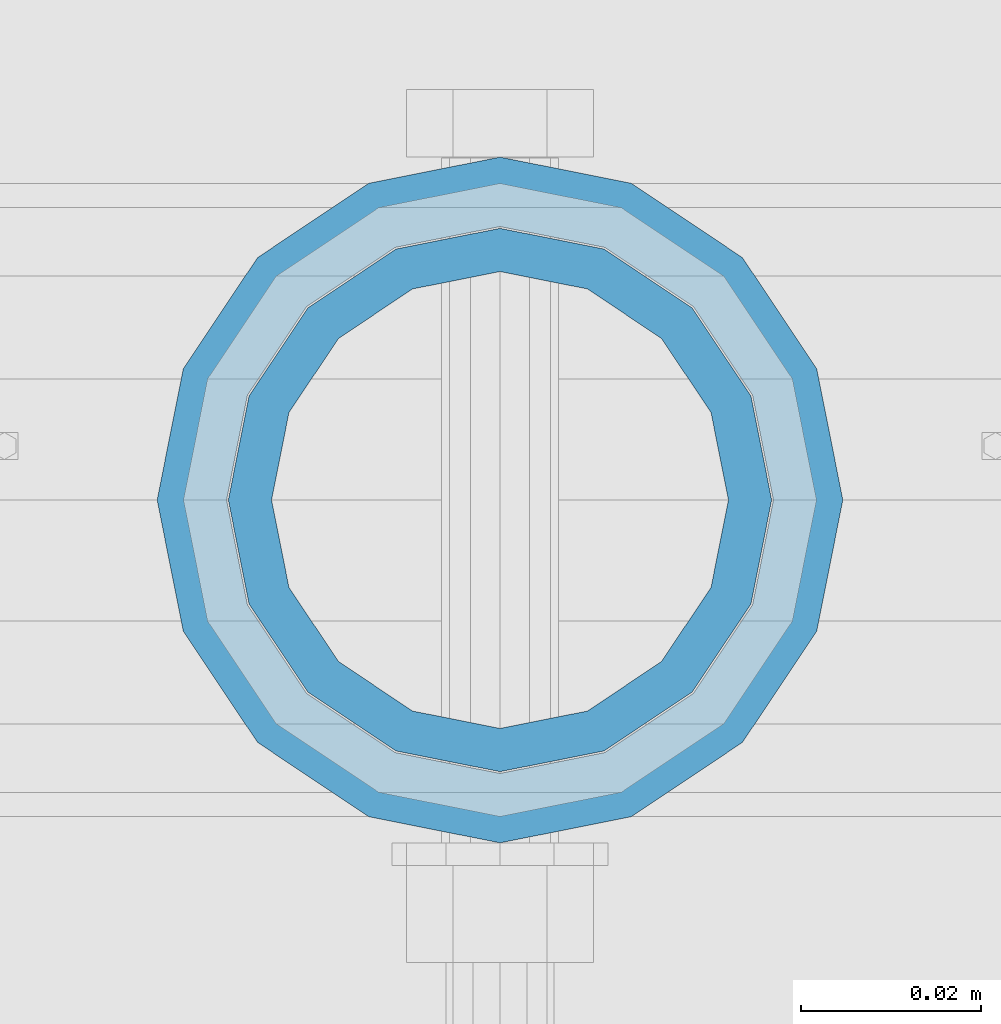
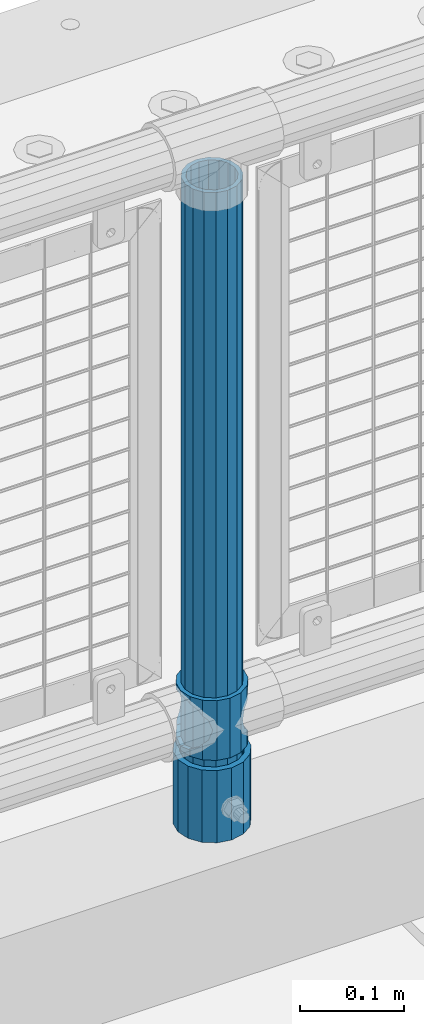
# One storey, part 55 of 193: 3 columns.
"""IFC2X3 building model written with IfcOpenShell, lengths in millimetres."""

from ifc_helpers import new_model, si_unit, frame, origin_with_axes, place, context, subcontext, project, spatial, faceted_brep, material, type_object, element, save


model = new_model("IFC2X3")

# Units and contexts
model_context = context("Model", 3, precision=1e-05, world=origin_with_axes())
body_context = subcontext(model_context, "Body", "Model", "MODEL_VIEW")
ifc_project = project(units=[si_unit("LENGTHUNIT", "METRE", prefix="MILLI"), si_unit("AREAUNIT", "SQUARE_METRE"), si_unit("VOLUMEUNIT", "CUBIC_METRE"), si_unit("MASSUNIT", "GRAM", prefix="KILO"), si_unit("TIMEUNIT", "SECOND"), si_unit("PLANEANGLEUNIT", "RADIAN"), si_unit("SOLIDANGLEUNIT", "STERADIAN"), si_unit("THERMODYNAMICTEMPERATUREUNIT", "DEGREE_CELSIUS"), si_unit("LUMINOUSINTENSITYUNIT", "LUMEN")], contexts=[model_context])

# Site, building, storey
site_placement = place(None, origin_with_axes())
site = spatial("IfcSite", under=ifc_project, at=site_placement, CompositionType="ELEMENT")
building_placement = place(site_placement, origin_with_axes())
building = spatial("IfcBuilding", under=site, at=building_placement, Name="Standard", CompositionType="ELEMENT")
storey_placement = place(building_placement, origin_with_axes())
storey = spatial("IfcBuildingStorey", under=building, at=storey_placement, Name="Undefined", CompositionType="ELEMENT", Elevation=0.0)

# Columns
ifc_material_1 = material(Name="Misc_Undefined")
column_type_1 = type_object("IfcColumnType", PredefinedType="NOTDEFINED")
column_1_placement = place(storey_placement, frame((-40171.0, 28664.5, 263.02), z_axis=(-1.0, 0.0, 0.0), x_axis=(0.0, 0.0, 1.0)))
element("IfcColumn", 1, at=column_1_placement, inside=storey, type_object=column_type_1, material=ifc_material_1, context=body_context, shape_type="Brep", body=[
    faceted_brep([(56.6106908090114, 21.46069080901, -21.46069080901), (56.6106908090114, 21.46069080901, -27.1226768591041), (61.9623795176744, 13.4513226476338, -32.4743655677703), (63.1897438117172, 11.614442172282, -32.8397438117245), (63.1897438117172, 11.614442172282, -28.0397438117179), (46.7644421722801, 28.0397438117179, -11.614442172282), (46.7644421722801, 28.0397438117179, -20.0882031229849), (51.5310424080006, 24.8548033587067, -24.8548033587067), (35.1500000000015, 30.35, 0.0), (35.1499999999996, 30.3499999999985, -16.6306603983685), (23.5355578277192, 28.0397438117179, -11.614442172282), (23.5355578277192, 28.0397438117179, -20.0882031229849), (13.6893091909879, 21.46069080901, -21.46069080901), (13.6893091909879, 21.46069080901, -27.1226768591041), (18.7689575919987, 24.8548033587067, -24.8548033587067), (7.11025618828211, 11.614442172282, -28.0397438117179), (7.11025618828211, 11.614442172282, -32.8397438117245), (8.33762048232262, 13.4513226476338, -32.4743655677703), (4.79999999999961, 0.0, -30.3499999999985), (4.79999999999961, 0.0, -35.1500000000015), (7.11025618828211, -11.614442172282, -28.0397438117179), (7.11025618828211, -11.614442172282, -32.8397438117172), (13.6893091909879, -21.46069080901, -21.46069080901), (13.6893091909879, -21.46069080901, -27.1226768591114), (8.33762048232484, -13.4513226476338, -32.4743655677703), (23.5355578277191, -28.0397438117179, -11.614442172282), (23.5355578277191, -28.0397438117179, -20.0882031229812), (18.7689575919921, -24.8548033587067, -24.8548033587067), (35.1500000000015, -30.35, 0.0), (35.1499999999996, -30.3499999999985, -16.6306603983721), (46.7644421722801, -28.0397438117179, -11.614442172282), (46.7644421722801, -28.0397438117179, -20.0882031229812), (56.6106908090114, -21.46069080901, -21.46069080901), (56.6106908090114, -21.46069080901, -27.1226768591114), (51.5310424080006, -24.8548033587067, -24.8548033587067), (63.1897438117172, -11.614442172282, -28.0397438117179), (63.1897438117172, -11.614442172282, -32.8397438117172), (61.9623795176767, -13.4513226476338, -32.4743655677703), (65.4999999999997, 0.0, -30.3499999999985), (65.4999999999997, 0.0, -35.1500000000015), (0.0, -28.0397438117179, -11.614442172282), (0.0, -30.3499999999985, 0.0), (0.0, -21.46069080901, -21.46069080901), (0.0, -11.614442172282, -28.0397438117179), (0.0, 0.0, -30.3499999999985), (0.0, 11.614442172282, -28.0397438117179), (0.0, 21.46069080901, -21.46069080901), (0.0, 28.0397438117179, -11.614442172282), (0.0, 30.3499999999985, 0.0), (0.0, 28.0397438117179, 11.614442172282), (23.5355578277192, 28.0397438117179, 11.614442172282), (0.0, 21.46069080901, 21.46069080901), (13.6893091909879, 21.46069080901, 21.46069080901), (0.0, 11.614442172282, 28.0397438117179), (7.11025618828211, 11.614442172282, 28.0397438117179), (0.0, 0.0, 30.3499999999985), (4.79999999999961, 0.0, 30.3499999999985), (0.0, -11.614442172282, 28.0397438117179), (7.11025618828205, -11.614442172282, 28.0397438117179), (0.0, -21.46069080901, 21.46069080901), (13.6893091909879, -21.46069080901, 21.46069080901), (0.0, -28.0397438117179, 11.614442172282), (23.5355578277191, -28.0397438117179, 11.614442172282), (0.0, -32.4743655677703, 13.4513226476338), (0.0, -35.1500000000015, 0.0), (70.2999999999993, -35.1500000000015, 0.0), (70.2999999999993, -32.4743655677703, 13.4513226476338), (0.0, 13.4513226476338, -32.4743655677703), (0.0, 24.8548033587067, -24.8548033587067), (0.0, 0.0, -35.1500000000015), (0.0, -13.4513226476338, -32.4743655677703), (0.0, -24.8548033587067, -24.8548033587067), (0.0, -24.8548033587067, 24.8548033587067), (0.0, -13.4513226476338, 32.4743655677703), (0.0, 0.0, 35.1500000000015), (0.0, 13.4513226476338, 32.4743655677703), (0.0, 24.8548033587067, 24.8548033587067), (0.0, 32.4743655677703, 13.4513226476338), (0.0, 35.1500000000015, 0.0), (0.0, 32.4743655677703, -13.4513226476338), (0.0, -32.4743655677703, -13.4513226476338), (70.2999999999993, 32.4743655677703, 13.4513226476338), (70.2999999999993, 35.1500000000015, 0.0), (70.2999999999993, 32.4743655677703, -13.4513226476338), (70.2999999999993, 24.8548033587067, -24.8548033587067), (70.2999999999993, 13.4513226476338, -32.4743655677703), (70.2999999999993, 0.0, -35.1500000000015), (70.2999999999993, -13.4513226476338, -32.4743655677703), (70.2999999999993, -24.8548033587067, -24.8548033587067), (70.2999999999993, -32.4743655677703, -13.4513226476338), (70.2999999999993, 28.0397438117179, 11.614442172282), (70.2999999999993, 21.46069080901, 21.46069080901), (56.6106908090114, 21.46069080901, 21.46069080901), (46.7644421722801, 28.0397438117179, 11.614442172282), (70.2999999999993, 11.614442172282, 28.0397438117179), (63.1897438117172, 11.614442172282, 28.0397438117179), (70.2999999999993, 0.0, 30.3499999999985), (65.4999999999997, 0.0, 30.3499999999985), (70.2999999999993, -11.614442172282, 28.0397438117179), (63.1897438117172, -11.614442172282, 28.0397438117179), (70.2999999999993, -21.46069080901, 21.46069080901), (56.6106908090114, -21.46069080901, 21.46069080901), (70.2999999999993, -28.0397438117179, 11.614442172282), (46.7644421722801, -28.0397438117179, 11.614442172282), (70.2999999999993, -11.614442172282, -28.0397438117179), (70.2999999999993, 0.0, -30.3499999999985), (70.2999999999993, -21.46069080901, -21.46069080901), (70.2999999999993, -28.0397438117179, -11.614442172282), (70.2999999999993, -30.3499999999985, 0.0), (70.2999999999993, 24.8548033587067, 24.8548033587067), (70.2999999999993, 13.4513226476338, 32.4743655677703), (70.2999999999993, 0.0, 35.1500000000015), (70.2999999999993, -13.4513226476338, 32.4743655677703), (70.2999999999993, -24.8548033587067, 24.8548033587067), (70.2999999999993, 30.3499999999985, 0.0), (70.2999999999993, 28.0397438117179, -11.614442172282), (70.2999999999993, 21.46069080901, -21.46069080901), (70.2999999999993, 11.614442172282, -28.0397438117179), (61.9623795176742, 13.4513226476338, 32.4743655677703), (51.5310424080006, 24.8548033587067, 24.8548033587067), (56.6106908090114, 21.46069080901, 27.1226768591077), (65.4999999999997, 0.0, 35.1500000000015), (63.1897438117172, 11.614442172282, 32.8397438117136), (63.1897438117172, -11.614442172282, 32.8397438117136), (61.9623795176767, -13.4513226476338, 32.4743655677703), (56.6106908090114, -21.46069080901, 27.1226768591041), (51.5310424080006, -24.8548033587067, 24.8548033587067), (18.7689575919921, -24.8548033587067, 24.8548033587067), (46.7644421722801, -28.0397438117179, 20.0882031229812), (35.1499999999996, -30.3499999999985, 16.6306603983685), (23.5355578277191, -28.0397438117179, 20.0882031229812), (8.33762048232512, -13.4513226476338, 32.4743655677703), (13.6893091909879, -21.46069080901, 27.1226768591041), (4.79999999999961, 0.0, 35.1500000000015), (7.11025618828205, -11.614442172282, 32.8397438117136), (7.11025618828211, 11.614442172282, 32.8397438117136), (8.3376204823229, 13.4513226476338, 32.4743655677703), (13.6893091909879, 21.46069080901, 27.1226768591077), (18.7689575919987, 24.8548033587067, 24.8548033587067), (23.5355578277192, 28.0397438117179, 20.0882031229739), (35.1499999999996, 30.3499999999985, 16.6306603983576), (46.7644421722801, 28.0397438117179, 20.0882031229739)], [[[0, 1, 2, 3, 4]], [[5, 6, 7, 1, 0]], [[8, 9, 6, 5]], [[10, 11, 9, 8]], [[12, 13, 14, 11, 10]], [[15, 16, 17, 13, 12]], [[18, 19, 16, 15]], [[20, 21, 19, 18]], [[22, 23, 24, 21, 20]], [[25, 26, 27, 23, 22]], [[28, 29, 26, 25]], [[30, 31, 29, 28]], [[32, 33, 34, 31, 30]], [[35, 36, 37, 33, 32]], [[38, 39, 36, 35]], [[4, 3, 39, 38]], [[40, 41, 28, 25]], [[42, 40, 25, 22]], [[43, 42, 22, 20]], [[44, 43, 20, 18]], [[45, 44, 18, 15]], [[46, 45, 15, 12]], [[47, 46, 12, 10]], [[48, 47, 10, 8]], [[49, 48, 8, 50]], [[51, 49, 50, 52]], [[53, 51, 52, 54]], [[55, 53, 54, 56]], [[57, 55, 56, 58]], [[59, 57, 58, 60]], [[61, 59, 60, 62]], [[41, 61, 62, 28]], [[63, 64, 65, 66]], [[17, 67, 68, 14, 13]], [[19, 69, 67, 17, 16]], [[70, 69, 19, 21, 24]], [[71, 70, 24, 23, 27]], [[63, 72, 73, 74, 75, 76, 77, 78, 79, 68, 67, 69, 70, 71, 80, 64], [40, 42, 43, 44, 45, 46, 47, 48, 49, 51, 53, 55, 57, 59, 61, 41]], [[78, 77, 81, 82]], [[79, 78, 82, 83]], [[14, 68, 79, 83, 84, 7, 6, 9, 11]], [[84, 85, 2, 1, 7]], [[85, 86, 39, 3, 2]], [[37, 87, 88, 34, 33]], [[39, 86, 87, 37, 36]], [[34, 88, 89, 80, 71, 27, 26, 29, 31]], [[64, 80, 89, 65]], [[90, 91, 92, 93]], [[91, 94, 95, 92]], [[94, 96, 97, 95]], [[96, 98, 99, 97]], [[98, 100, 101, 99]], [[100, 102, 103, 101]], [[104, 105, 38, 35]], [[106, 104, 35, 32]], [[107, 106, 32, 30]], [[108, 107, 30, 28]], [[102, 108, 28, 103]], [[88, 87, 86, 85, 84, 83, 82, 81, 109, 110, 111, 112, 113, 66, 65, 89], [100, 98, 96, 94, 91, 90, 114, 115, 116, 117, 105, 104, 106, 107, 108, 102]], [[118, 110, 109, 119, 120]], [[121, 111, 110, 118, 122]], [[112, 111, 121, 123, 124]], [[113, 112, 124, 125, 126]], [[127, 72, 63, 66, 113, 126, 128, 129, 130]], [[131, 73, 72, 127, 132]], [[133, 74, 73, 131, 134]], [[75, 74, 133, 135, 136]], [[76, 75, 136, 137, 138]], [[119, 109, 81, 77, 76, 138, 139, 140, 141]], [[92, 120, 119, 141, 93]], [[95, 122, 118, 120, 92]], [[97, 121, 122, 95]], [[99, 123, 121, 97]], [[101, 125, 124, 123, 99]], [[103, 128, 126, 125, 101]], [[28, 129, 128, 103]], [[62, 130, 129, 28]], [[60, 132, 127, 130, 62]], [[58, 134, 131, 132, 60]], [[56, 133, 134, 58]], [[54, 135, 133, 56]], [[52, 137, 136, 135, 54]], [[50, 139, 138, 137, 52]], [[8, 140, 139, 50]], [[93, 141, 140, 8]], [[114, 90, 93, 8]], [[115, 114, 8, 5]], [[116, 115, 5, 0]], [[117, 116, 0, 4]], [[105, 117, 4, 38]]]),
])
ifc_material_2 = material()
column_type_2 = type_object("IfcColumnType", PredefinedType="NOTDEFINED")
column_2_placement = place(storey_placement, frame((-40171.0, 28664.5, 168.02), z_axis=(-1.0, 0.0, 0.0), x_axis=(0.0, 0.0, 1.0)))
element("IfcColumn", 2, at=column_2_placement, inside=storey, type_object=column_type_2, material=ifc_material_2, context=body_context, shape_type="Brep", body=[
    faceted_brep([(0.0, -25.3499999999985, 0.0), (0.0, -23.4203461491597, 9.70102501045403), (760.0, -23.4203461491597, 9.70102501045403), (760.0, -25.3499999999985, 0.0), (0.0, -17.9251569030785, 17.9251569030785), (760.0, -17.9251569030785, 17.9251569030785), (0.0, -9.70102501045403, 23.4203461491597), (760.0, -9.70102501045403, 23.4203461491597), (0.0, 0.0, 25.3499999999985), (760.0, 0.0, 25.3499999999985), (0.0, 9.70102501045403, 23.4203461491597), (760.0, 9.70102501045403, 23.4203461491597), (0.0, 17.9251569030785, 17.9251569030785), (760.0, 17.9251569030785, 17.9251569030785), (0.0, 23.4203461491597, 9.70102501045403), (760.0, 23.4203461491597, 9.70102501045403), (0.0, 25.3499999999985, 0.0), (760.0, 25.3499999999985, 0.0), (0.0, 23.4203461491597, -9.70102501045403), (760.0, 23.4203461491597, -9.70102501045403), (0.0, 17.9251569030785, -17.9251569030785), (760.0, 17.9251569030785, -17.9251569030785), (0.0, 9.70102501045403, -23.4203461491597), (760.0, 9.70102501045403, -23.4203461491597), (0.0, 0.0, -25.3499999999985), (760.0, 0.0, -25.3499999999985), (0.0, -9.70102501045403, -23.4203461491597), (760.0, -9.70102501045403, -23.4203461491597), (0.0, -17.9251569030785, -17.9251569030785), (760.0, -17.9251569030785, -17.9251569030785), (0.0, -23.4203461491597, -9.70102501045403), (760.0, -23.4203461491597, -9.70102501045403), (0.0, -30.1500000000015, 0.0), (0.0, -27.8549679052157, -11.5379054858058), (760.0, -27.8549679052157, -11.5379054858058), (760.0, -30.1500000000015, 0.0), (0.0, -21.3192694527752, -21.3192694527752), (760.0, -21.3192694527752, -21.3192694527752), (0.0, -11.5379054858058, -27.8549679052157), (760.0, -11.5379054858058, -27.8549679052157), (0.0, 0.0, -30.1500000000015), (760.0, 0.0, -30.1500000000015), (0.0, 11.5379054858058, -27.8549679052157), (760.0, 11.5379054858058, -27.8549679052157), (0.0, 21.3192694527752, -21.3192694527752), (760.0, 21.3192694527752, -21.3192694527752), (0.0, 27.8549679052157, -11.5379054858058), (760.0, 27.8549679052157, -11.5379054858058), (0.0, 30.1500000000015, 0.0), (760.0, 30.1500000000015, 0.0), (0.0, 27.8549679052157, 11.5379054858058), (760.0, 27.8549679052157, 11.5379054858058), (0.0, 21.3192694527752, 21.3192694527752), (760.0, 21.3192694527752, 21.3192694527752), (0.0, 11.5379054858058, 27.8549679052157), (760.0, 11.5379054858058, 27.8549679052157), (0.0, 0.0, 30.1500000000015), (760.0, 0.0, 30.1500000000015), (0.0, -11.5379054858058, 27.8549679052157), (760.0, -11.5379054858058, 27.8549679052157), (0.0, -21.3192694527752, 21.3192694527752), (760.0, -21.3192694527752, 21.3192694527752), (0.0, -27.8549679052157, 11.5379054858058), (760.0, -27.8549679052157, 11.5379054858058)], [[[0, 1, 2, 3]], [[1, 4, 5, 2]], [[4, 6, 7, 5]], [[6, 8, 9, 7]], [[8, 10, 11, 9]], [[10, 12, 13, 11]], [[12, 14, 15, 13]], [[14, 16, 17, 15]], [[16, 18, 19, 17]], [[18, 20, 21, 19]], [[20, 22, 23, 21]], [[22, 24, 25, 23]], [[24, 26, 27, 25]], [[26, 28, 29, 27]], [[28, 30, 31, 29]], [[30, 0, 3, 31]], [[32, 33, 34, 35]], [[33, 36, 37, 34]], [[36, 38, 39, 37]], [[38, 40, 41, 39]], [[40, 42, 43, 41]], [[42, 44, 45, 43]], [[44, 46, 47, 45]], [[46, 48, 49, 47]], [[48, 50, 51, 49]], [[50, 52, 53, 51]], [[52, 54, 55, 53]], [[54, 56, 57, 55]], [[56, 58, 59, 57]], [[58, 60, 61, 59]], [[60, 62, 63, 61]], [[62, 32, 35, 63]], [[37, 39, 41, 43, 45, 47, 49, 51, 53, 55, 57, 59, 61, 63, 35, 34], [5, 7, 9, 11, 13, 15, 17, 19, 21, 23, 25, 27, 29, 31, 3, 2]], [[62, 60, 58, 56, 54, 52, 50, 48, 46, 44, 42, 40, 38, 36, 33, 32], [30, 28, 26, 24, 22, 20, 18, 16, 14, 12, 10, 8, 6, 4, 1, 0]]]),
])
column_type_3 = type_object("IfcColumnType", PredefinedType="NOTDEFINED")
column_3_placement = place(storey_placement, frame((-40171.0, 28664.5, 168.02), z_axis=(0.0, 1.0, 0.0), x_axis=(0.0, 0.0, 1.0)))
element("IfcColumn", 3, at=column_3_placement, inside=storey, type_object=column_type_3, material=ifc_material_2, context=body_context, shape_type="Brep", body=[
    faceted_brep([(0.0, -31.75, 0.0), (0.0, -29.3331751572332, 12.1501989775934), (85.0, -29.3331751572332, 12.1501989775934), (85.0, -31.75, 0.0), (0.0, -22.4506403026717, 22.4506403026717), (85.0, -22.4506403026717, 22.4506403026717), (0.0, -12.1501989775934, 29.3331751572332), (85.0, -12.1501989775934, 29.3331751572332), (0.0, 0.0, 31.75), (85.0, 0.0, 31.75), (0.0, 12.1501989775934, 29.3331751572332), (85.0, 12.1501989775934, 29.3331751572332), (0.0, 22.4506403026717, 22.4506403026717), (85.0, 22.4506403026717, 22.4506403026717), (0.0, 29.3331751572332, 12.1501989775934), (85.0, 29.3331751572332, 12.1501989775934), (0.0, 31.75, 0.0), (85.0, 31.75, 0.0), (0.0, 29.3331751572332, -12.1501989775934), (85.0, 29.3331751572332, -12.1501989775934), (0.0, 22.4506403026717, -22.4506403026717), (85.0, 22.4506403026717, -22.4506403026717), (0.0, 12.1501989775934, -29.3331751572332), (85.0, 12.1501989775934, -29.3331751572332), (0.0, 0.0, -31.75), (85.0, 0.0, -31.75), (0.0, -12.1501989775934, -29.3331751572332), (85.0, -12.1501989775934, -29.3331751572332), (0.0, -22.4506403026717, -22.4506403026717), (85.0, -22.4506403026717, -22.4506403026717), (0.0, -29.3331751572332, -12.1501989775934), (85.0, -29.3331751572332, -12.1501989775934), (0.0, -38.0499999999993, 0.0), (0.0, -35.1536162120537, -14.5611046014928), (85.0, -35.1536162120537, -14.5611046014928), (85.0, -38.0499999999993, 0.0), (0.0, -26.9054130241493, -26.9054130241493), (85.0, -26.9054130241493, -26.9054130241493), (0.0, -14.5611046014928, -35.1536162120537), (85.0, -14.5611046014928, -35.1536162120537), (0.0, 0.0, -38.0499999999993), (85.0, 0.0, -38.0499999999993), (0.0, 14.5611046014928, -35.1536162120537), (85.0, 14.5611046014928, -35.1536162120537), (0.0, 26.9054130241493, -26.9054130241493), (85.0, 26.9054130241493, -26.9054130241493), (0.0, 35.1536162120537, -14.5611046014928), (85.0, 35.1536162120537, -14.5611046014928), (0.0, 38.0499999999993, 0.0), (85.0, 38.0499999999993, 0.0), (0.0, 35.1536162120537, 14.5611046014928), (85.0, 35.1536162120537, 14.5611046014928), (0.0, 26.9054130241493, 26.9054130241493), (85.0, 26.9054130241493, 26.9054130241493), (0.0, 14.5611046014928, 35.1536162120537), (85.0, 14.5611046014928, 35.1536162120537), (0.0, 0.0, 38.0499999999993), (85.0, 0.0, 38.0499999999993), (0.0, -14.5611046014928, 35.1536162120537), (85.0, -14.5611046014928, 35.1536162120537), (0.0, -26.9054130241493, 26.9054130241493), (85.0, -26.9054130241493, 26.9054130241493), (0.0, -35.1536162120537, 14.5611046014928), (85.0, -35.1536162120537, 14.5611046014928)], [[[0, 1, 2, 3]], [[1, 4, 5, 2]], [[4, 6, 7, 5]], [[6, 8, 9, 7]], [[8, 10, 11, 9]], [[10, 12, 13, 11]], [[12, 14, 15, 13]], [[14, 16, 17, 15]], [[16, 18, 19, 17]], [[18, 20, 21, 19]], [[20, 22, 23, 21]], [[22, 24, 25, 23]], [[24, 26, 27, 25]], [[26, 28, 29, 27]], [[28, 30, 31, 29]], [[30, 0, 3, 31]], [[32, 33, 34, 35]], [[33, 36, 37, 34]], [[36, 38, 39, 37]], [[38, 40, 41, 39]], [[40, 42, 43, 41]], [[42, 44, 45, 43]], [[44, 46, 47, 45]], [[46, 48, 49, 47]], [[48, 50, 51, 49]], [[50, 52, 53, 51]], [[52, 54, 55, 53]], [[54, 56, 57, 55]], [[56, 58, 59, 57]], [[58, 60, 61, 59]], [[60, 62, 63, 61]], [[62, 32, 35, 63]], [[37, 39, 41, 43, 45, 47, 49, 51, 53, 55, 57, 59, 61, 63, 35, 34], [5, 7, 9, 11, 13, 15, 17, 19, 21, 23, 25, 27, 29, 31, 3, 2]], [[62, 60, 58, 56, 54, 52, 50, 48, 46, 44, 42, 40, 38, 36, 33, 32], [30, 28, 26, 24, 22, 20, 18, 16, 14, 12, 10, 8, 6, 4, 1, 0]]]),
])

save(model, "model.ifc")
